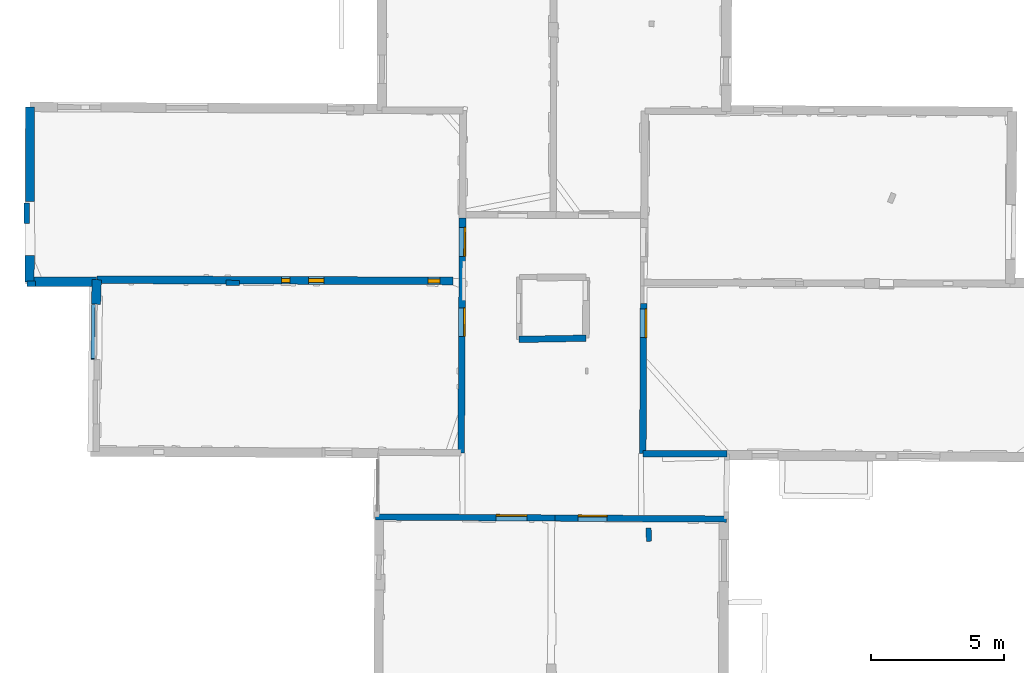
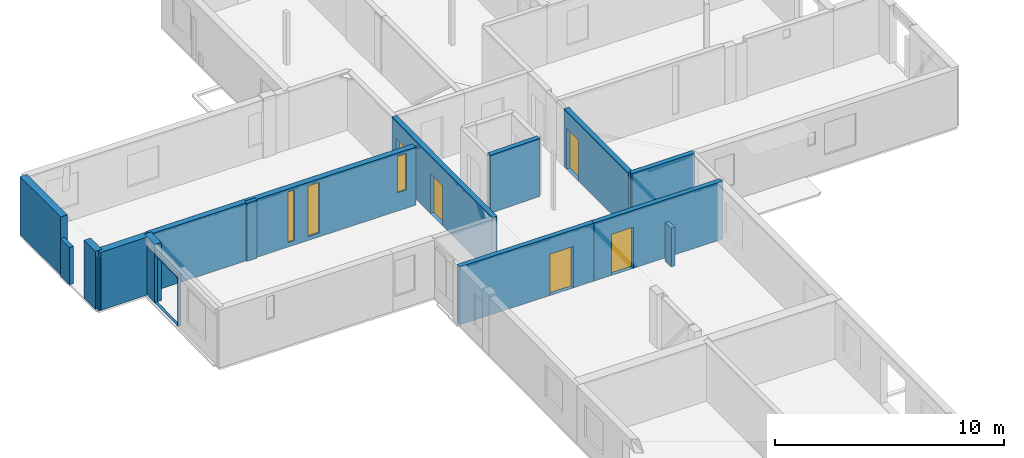
# One storey, part 9 of 17: 16 walls, 5 doors, 3 windows, 9 openings.
"""IFC2X3 building model written with IfcOpenShell, lengths in metres."""

from ifc_helpers import new_model, entity, si_unit, converted_unit, derived_unit, direction, frame, frame_2d, origin, origin_2d_with_axis, place, context, subcontext, project, spatial, polyline, rectangle, outline, extrude, clip, halfspace, source, transform, mapped, material, layer, layer_set, layer_usage, type_object, type_shapes, element, fill, save


model = new_model("IFC2X3")

# Units and contexts
model_context = context("Model", 3, precision=1e-05, world=origin(), true_north=direction((0.0, 1.0)))
body_context = subcontext(model_context, "Body", "Model", "MODEL_VIEW")
ifc_project = project(units=[si_unit("LENGTHUNIT", "METRE"), si_unit("AREAUNIT", "SQUARE_METRE"), si_unit("VOLUMEUNIT", "CUBIC_METRE"), converted_unit("PLANEANGLEUNIT", "DEGREE", entity("IfcRatioMeasure", 0.0174532925199433), si_unit("PLANEANGLEUNIT", "RADIAN"), dimensions=[0, 0, 0, 0, 0, 0, 0]), si_unit("MASSUNIT", "GRAM", prefix="KILO"), derived_unit("MASSDENSITYUNIT", [(si_unit("MASSUNIT", "GRAM", prefix="KILO"), 1), (si_unit("LENGTHUNIT", "METRE"), -3)]), derived_unit("MOMENTOFINERTIAUNIT", [(si_unit("LENGTHUNIT", "METRE"), 4)]), si_unit("TIMEUNIT", "SECOND"), si_unit("FREQUENCYUNIT", "HERTZ"), si_unit("THERMODYNAMICTEMPERATUREUNIT", "DEGREE_CELSIUS"), derived_unit("THERMALTRANSMITTANCEUNIT", [(si_unit("MASSUNIT", "GRAM", prefix="KILO"), 1), (si_unit("THERMODYNAMICTEMPERATUREUNIT", "KELVIN"), -1), (si_unit("TIMEUNIT", "SECOND"), -3)]), derived_unit("VOLUMETRICFLOWRATEUNIT", [(si_unit("LENGTHUNIT", "METRE"), 3), (si_unit("TIMEUNIT", "SECOND"), -1)]), si_unit("ELECTRICCURRENTUNIT", "AMPERE"), si_unit("ELECTRICVOLTAGEUNIT", "VOLT"), si_unit("POWERUNIT", "WATT"), si_unit("FORCEUNIT", "NEWTON", prefix="KILO"), si_unit("ILLUMINANCEUNIT", "LUX"), si_unit("LUMINOUSFLUXUNIT", "LUMEN"), si_unit("LUMINOUSINTENSITYUNIT", "CANDELA"), derived_unit("USERDEFINED", [(si_unit("MASSUNIT", "GRAM", prefix="KILO"), -1), (si_unit("LENGTHUNIT", "METRE"), -2), (si_unit("TIMEUNIT", "SECOND"), 3), (si_unit("LUMINOUSFLUXUNIT", "LUMEN"), 1)]), derived_unit("LINEARVELOCITYUNIT", [(si_unit("LENGTHUNIT", "METRE"), 1), (si_unit("TIMEUNIT", "SECOND"), -1)]), si_unit("PRESSUREUNIT", "PASCAL"), derived_unit("USERDEFINED", [(si_unit("LENGTHUNIT", "METRE"), -2), (si_unit("MASSUNIT", "GRAM", prefix="KILO"), 1), (si_unit("TIMEUNIT", "SECOND"), -2)]), derived_unit("LINEARFORCEUNIT", [(si_unit("MASSUNIT", "GRAM", prefix="KILO"), 1), (si_unit("LENGTHUNIT", "METRE"), 1), (si_unit("TIMEUNIT", "SECOND"), -2), (si_unit("LENGTHUNIT", "METRE"), -1)]), derived_unit("PLANARFORCEUNIT", [(si_unit("MASSUNIT", "GRAM", prefix="KILO"), 1), (si_unit("LENGTHUNIT", "METRE"), 1), (si_unit("TIMEUNIT", "SECOND"), -2), (si_unit("LENGTHUNIT", "METRE"), -2)])], contexts=[model_context])

# Site, building, storey
placement = place(None, origin())
site = spatial("IfcSite", under=ifc_project, at=placement, CompositionType="ELEMENT")
building = spatial("IfcBuilding", under=site, at=placement, CompositionType="ELEMENT")
storey_placement = place(placement, frame((0.0, 0.0, 12.0782108306885)))
storey = spatial("IfcBuildingStorey", under=building, at=storey_placement, Name="Level 5", CompositionType="ELEMENT", Elevation=12.0782108306885)

# Wall, openings, doors
ifc_material_1 = material(Name="Default wall")
ifc_layer_1 = layer(ifc_material_1, 0.25)
ifc_layer_set_1 = layer_set([ifc_layer_1], Name="wall_thickness_0.2500")
ifc_layer_usage_1 = layer_usage(ifc_layer_set_1, "AXIS2", "POSITIVE", -0.125)
wall_type_1 = type_object("IfcWallType", Name="wall_thickness_0.2500", PredefinedType="STANDARD", material=ifc_layer_set_1)
wall_1_placement = place(storey_placement, frame((2.97258634511656, 60.0444172473294, 0.0), z_axis=(0.0, 0.0, 1.0), x_axis=(-0.00545394722210246, -0.999985127119248, 0.0)))
wall_1 = element("IfcWallStandardCase", 1, at=wall_1_placement, inside=storey, type_object=wall_type_1, material=ifc_layer_usage_1, Name="Wall:293", ObjectType="Wall", context=body_context, shape_type="Clipping", body=[
    clip(clip(extrude(outline(polyline([(8.83394409982021, -0.125), (8.83394409982021, 0.125), (0.0, 0.125), (0.0, -0.125), (8.83394409982021, -0.125)])), origin(), (0.0, 0.0, 1.0), 3.09134044647217), halfspace(frame((2.3229233307101, -15.7133209596465, 9.01748660239985), z_axis=(0.391125818460587, -0.00175486266709377, 0.920335544565435), x_axis=(0.00269607752572653, 0.999996076035837, 0.000760972341273259)), False)), halfspace(frame((-15.776051598022, -4.32149318367939, 5.79573318480268), z_axis=(0.00071207565798615, -0.389900123542351, 0.920856876289642), x_axis=(0.00052470655725931, 0.920855864477366, 0.389902810378011)), False)),
])
opening_1_placement = place(wall_1_placement, frame((0.35520700321392, -0.125, 0.00578975677490234)))
opening_1 = element("IfcOpeningElement", 2, at=opening_1_placement, cuts=wall_1, Name="Opening : 1085 x 2155 : 246", ObjectType="Opening", context=body_context, shape_type="SweptSolid", body=[
    extrude(rectangle(XDim=1.085, YDim=2.155, at=frame_2d((1.0775, 0.5425), x_axis=(0.0, 1.0))), frame((0.0, 0.0, 0.0), z_axis=(0.0, 1.0, 0.0), x_axis=(0.0, 0.0, 1.0)), (0.0, 0.0, 1.0), 0.25),
])
opening_2_placement = place(wall_1_placement, frame((3.3853538461384, -0.125, 0.00578975677490234)))
opening_2 = element("IfcOpeningElement", 3, at=opening_2_placement, cuts=wall_1, Name="Opening : 1070 x 2125 : 247", ObjectType="Opening", context=body_context, shape_type="SweptSolid", body=[
    extrude(rectangle(XDim=1.07, YDim=2.125, at=frame_2d((1.0625, 0.535), x_axis=(0.0, 1.0))), frame((0.0, 0.0, 0.0), z_axis=(0.0, 1.0, 0.0), x_axis=(0.0, 0.0, 1.0)), (0.0, 0.0, 1.0), 0.25),
])
ifc_material_2 = material(Name="Door Panel")
door_style_1 = type_object("IfcDoorStyle", Name="Door : 1085 x 2155mm", ConstructionType="NOTDEFINED", OperationType="SINGLE_SWING_RIGHT", ParameterTakesPrecedence=False, Sizeable=False, material=ifc_material_2)
shared_shape_1 = source(origin(), body_context, "Body", "SweptSolid", [
    extrude(rectangle(XDim=0.0625, YDim=1.085, at=origin_2d_with_axis()), frame((0.5425, 0.21875, 0.0), z_axis=(0.0, 0.0, 1.0), x_axis=(0.0, 1.0, 0.0)), (0.0, 0.0, 1.0), 2.155),
])
type_shapes(door_style_1, [shared_shape_1])
door_1_placement = place(opening_1_placement, origin())
door_1 = element("IfcDoor", 4, at=door_1_placement, inside=storey, type_object=door_style_1, Name="Door : 1085 x 2155mm : 46", ObjectType="Door : 1085 x 2155mm", OverallHeight=2.155, OverallWidth=1.085, context=body_context, shape_type="MappedRepresentation", body=[
    mapped(shared_shape_1, transform((0.0, 0.0, 0.0), scale=1.0)),
])
fill(opening_1, door_1)
door_style_2 = type_object("IfcDoorStyle", Name="Door : 1070 x 2125mm", ConstructionType="NOTDEFINED", OperationType="SINGLE_SWING_RIGHT", ParameterTakesPrecedence=False, Sizeable=False, material=ifc_material_2)
shared_shape_2 = source(origin(), body_context, "Body", "SweptSolid", [
    extrude(rectangle(XDim=0.0625, YDim=1.07, at=origin_2d_with_axis()), frame((0.535, 0.21875, 0.0), z_axis=(0.0, 0.0, 1.0), x_axis=(0.0, 1.0, 0.0)), (0.0, 0.0, 1.0), 2.125),
])
type_shapes(door_style_2, [shared_shape_2])
door_2_placement = place(opening_2_placement, origin())
door_2 = element("IfcDoor", 5, at=door_2_placement, inside=storey, type_object=door_style_2, Name="Door : 1070 x 2125mm : 47", ObjectType="Door : 1070 x 2125mm", OverallHeight=2.125, OverallWidth=1.07, context=body_context, shape_type="MappedRepresentation", body=[
    mapped(shared_shape_2, transform((0.0, 0.0, 0.0), scale=1.0)),
])
fill(opening_2, door_2)

# Wall, opening, door
wall_2_placement = place(storey_placement, frame((9.78507749361691, 56.829574594409, 0.0), z_axis=(0.0, 0.0, 1.0), x_axis=(-0.00491332760453561, -0.999987929533077, 0.0)))
wall_2 = element("IfcWallStandardCase", 6, at=wall_2_placement, inside=storey, type_object=wall_type_1, material=ifc_layer_usage_1, Name="Wall:296", ObjectType="Wall", context=body_context, shape_type="Clipping", body=[
    clip(clip(extrude(outline(polyline([(5.64945936592881, -0.125), (5.64945936592881, 0.125), (0.0, 0.125), (0.0, -0.125), (5.64945936592881, -0.125)])), origin(), (0.0, 0.0, 1.0), 3.09134044647217), halfspace(frame((-0.866903899601547, -22.5427789917732, 9.01748660239985), z_axis=(0.391124812576068, -0.00196631553421412, 0.920335544565435), x_axis=(0.00323670187153783, 0.999994472325768, 0.000760972341273259)), False)), halfspace(frame((-20.421691617326, 2.93114393111947, 6.35864093399329), z_axis=(-1.48563875049452e-05, 0.390500122452484, 0.920602875372374), x_axis=(0.673609083494681, -0.680402403832266, 0.288623234499112)), False)),
])
opening_3_placement = place(wall_2_placement, frame((0.200724172085112, -0.125, 0.00578975677490234)))
opening_3 = element("IfcOpeningElement", 7, at=opening_3_placement, cuts=wall_2, Name="Opening : 1085 x 2185 : 249", ObjectType="Opening", context=body_context, shape_type="SweptSolid", body=[
    extrude(rectangle(XDim=1.085, YDim=2.185, at=frame_2d((1.0925, 0.5425), x_axis=(0.0, 1.0))), frame((0.0, 0.0, 0.0), z_axis=(0.0, 1.0, 0.0), x_axis=(0.0, 0.0, 1.0)), (0.0, 0.0, 1.0), 0.25),
])
door_style_3 = type_object("IfcDoorStyle", Name="Door : 1085 x 2185mm", ConstructionType="NOTDEFINED", OperationType="SINGLE_SWING_RIGHT", ParameterTakesPrecedence=False, Sizeable=False, material=ifc_material_2)
shared_shape_3 = source(origin(), body_context, "Body", "SweptSolid", [
    extrude(rectangle(XDim=0.0625, YDim=1.085, at=origin_2d_with_axis()), frame((0.5425, 0.21875, 0.0), z_axis=(0.0, 0.0, 1.0), x_axis=(0.0, 1.0, 0.0)), (0.0, 0.0, 1.0), 2.185),
])
type_shapes(door_style_3, [shared_shape_3])
door_3_placement = place(opening_3_placement, origin())
door_3 = element("IfcDoor", 8, at=door_3_placement, inside=storey, type_object=door_style_3, Name="Door : 1085 x 2185mm : 49", ObjectType="Door : 1085 x 2185mm", OverallHeight=2.185, OverallWidth=1.085, context=body_context, shape_type="MappedRepresentation", body=[
    mapped(shared_shape_3, transform((0.0, 0.0, 0.0), scale=1.0)),
])
fill(opening_3, door_3)

# Walls
ifc_layer_2 = layer(ifc_material_1, 0.349999994039536)
ifc_layer_set_2 = layer_set([ifc_layer_2], Name="wall_thickness_0.3500")
ifc_layer_usage_2 = layer_usage(ifc_layer_set_2, "AXIS2", "POSITIVE", -0.174999997019768)
wall_type_2 = type_object("IfcWallType", Name="wall_thickness_0.3500", PredefinedType="STANDARD", material=ifc_layer_set_2)
wall_3_placement = place(storey_placement, frame((-10.786523732517, 57.7226371348362, 0.0), z_axis=(0.0, 0.0, 1.0), x_axis=(-0.0302345456324887, -0.999542831623736, 0.0)))
element("IfcWallStandardCase", 9, at=wall_3_placement, inside=storey, type_object=wall_type_2, material=ifc_layer_usage_2, Name="Wall:325", ObjectType="Wall", context=body_context, shape_type="Clipping", body=[
    clip(extrude(outline(polyline([(0.922556162917075, -0.174999997019768), (0.922556162917075, 0.174999997019768), (0.0, 0.174999997019768), (0.0, -0.174999997019768), (0.922556162917075, -0.174999997019768)])), origin(), (0.0, 0.0, 1.0), 3.09134044647217), halfspace(frame((-0.0250916245106704, -1.9683047614688, 9.01748660239985), z_axis=(0.391049179445526, 0.00793880749390821, 0.920335544565435), x_axis=(-0.0220872954005997, 0.999755756324005, 0.000760972341273259)), False)),
])
wall_4_placement = place(storey_placement, frame((-13.2988979832564, 64.2230248395409, 0.0), z_axis=(0.0, 0.0, 1.0), x_axis=(-0.00072722175541254, -0.999999735574224, 0.0)))
element("IfcWallStandardCase", 10, at=wall_4_placement, inside=storey, type_object=wall_type_2, material=ifc_layer_usage_2, Name="Wall:353", ObjectType="Wall", context=body_context, shape_type="SweptSolid", body=[
    extrude(outline(polyline([(3.55125521150435, -0.174999997019768), (3.55125521150435, 0.174999997019768), (0.0, 0.174999997019768), (0.0, -0.174999997019768), (3.55125521150435, -0.174999997019768)])), origin(), (0.0, 0.0, 1.0), 3.09134044647217),
])
ifc_layer_3 = layer(ifc_material_1, 0.2)
ifc_layer_set_3 = layer_set([ifc_layer_3], Name="wall_thickness_0.2000")
ifc_layer_usage_3 = layer_usage(ifc_layer_set_3, "AXIS2", "POSITIVE", -0.1)
wall_type_3 = type_object("IfcWallType", Name="wall_thickness_0.2000", PredefinedType="STANDARD", material=ifc_layer_set_3)
wall_5_placement = place(storey_placement, frame((-5.92594383292661, 57.6032597839898, 0.0), z_axis=(0.0, 0.0, 1.0), x_axis=(0.999982178277312, -0.00597018657677781, 0.0)))
element("IfcWallStandardCase", 11, at=wall_5_placement, inside=storey, type_object=wall_type_3, material=ifc_layer_usage_3, Name="Wall:298", ObjectType="Wall", context=body_context, shape_type="Clipping", body=[
    clip(extrude(outline(polyline([(0.514999984766503, -0.1), (0.514999984766503, 0.1), (0.0, 0.1), (0.0, -0.1), (0.514999984766503, -0.1)])), origin(), (0.0, 0.0, 1.0), 3.09134044647217), halfspace(frame((-6.82832223640236, 0.163204855223103, 9.01748660239985), z_axis=(-0.00155294460577056, -0.391126672284691, 0.920335544565435), x_axis=(0.999997334624458, -0.00217983143265884, 0.000760972341273259)), False)),
])
wall_6_placement = place(storey_placement, frame((-13.4037424072061, 57.5677008523582, 0.0), z_axis=(0.0, 0.0, 1.0), x_axis=(0.999998958154798, 0.001443498984781, 0.0)))
element("IfcWallStandardCase", 12, at=wall_6_placement, inside=storey, type_object=wall_type_3, material=ifc_layer_usage_3, Name="Wall:317", ObjectType="Wall", context=body_context, shape_type="SweptSolid", body=[
    extrude(outline(polyline([(0.317120882453858, -0.1), (0.317120882453858, 0.1), (0.0, 0.1), (0.0, -0.1), (0.317120882453858, -0.1)])), origin(), (0.0, 0.0, 1.0), 2.77079010009766),
])
wall_7_placement = place(storey_placement, frame((9.96924737158519, 48.3854746875862, 0.0), z_axis=(0.0, 0.0, 1.0), x_axis=(0.0427961878833052, -0.999083823461604, 0.0)))
element("IfcWallStandardCase", 13, at=wall_7_placement, inside=storey, type_object=wall_type_3, material=ifc_layer_usage_3, Name="Wall:346", ObjectType="Wall", context=body_context, shape_type="Clipping", body=[
    clip(extrude(outline(polyline([(0.505002160877729, -0.1), (0.505002160877729, 0.1), (0.0, 0.1), (0.0, -0.1), (0.505002160877729, -0.1)])), origin(), (0.0, 0.0, 1.0), 2.07478904724121), halfspace(frame((-28.7028580065749, 4.07938747716486, 6.35864093399329), z_axis=(0.0186137726193946, 0.390056243796956, 0.920602875372374), x_axis=(0.640383919674725, -0.711761943299378, 0.288623234499112)), False)),
])
wall_8_placement = place(storey_placement, frame((-13.4191786365824, 59.829089680565, 0.0), z_axis=(0.0, 0.0, 1.0), x_axis=(-0.00423869144538484, 0.999991016707066, 0.0)))
element("IfcWallStandardCase", 14, at=wall_8_placement, inside=storey, type_object=wall_type_3, material=ifc_layer_usage_3, Name="Wall:350", ObjectType="Wall", context=body_context, shape_type="SweptSolid", body=[
    extrude(outline(polyline([(0.784999269895973, -0.1), (0.784999269895973, 0.1), (0.0, 0.1), (0.0, -0.1), (0.784999269895973, -0.1)])), origin(), (0.0, 0.0, 1.0), 1.99078941345215),
])
ifc_layer_4 = layer(ifc_material_1, 0.239999994635582)
ifc_layer_set_4 = layer_set([ifc_layer_4], Name="wall_thickness_0.2400")
ifc_layer_usage_4 = layer_usage(ifc_layer_set_4, "AXIS2", "POSITIVE", -0.119999997317791)
wall_type_4 = type_object("IfcWallType", Name="wall_thickness_0.2400", PredefinedType="STANDARD", material=ifc_layer_set_4)
wall_9_placement = place(storey_placement, frame((9.75732022944128, 51.1801839236183, 0.0), z_axis=(0.0, 0.0, 1.0), x_axis=(0.999995397319388, -0.00303403032941338, 0.0)))
element("IfcWallStandardCase", 15, at=wall_9_placement, inside=storey, type_object=wall_type_4, material=ifc_layer_usage_4, Name="Wall:254", ObjectType="Wall", context=body_context, shape_type="Clipping", body=[
    clip(clip(extrude(outline(polyline([(3.16086125863991, -0.119999997317791), (3.16086125863991, 0.119999997317791), (0.0, 0.119999997317791), (0.0, -0.119999997317791), (3.16086125863991, -0.119999997317791)])), origin(), (0.0, 0.0, 1.0), 3.09134044647217), halfspace(frame((-22.5304932872622, 6.55871615246608, 9.01748660239985), z_axis=(-0.00270135733514378, -0.391120426567052, 0.920335544565435), x_axis=(0.999986623658175, -0.00511599705040992, 0.000760972341273259)), False)), halfspace(frame((2.98013418424224, 26.0655959074875, 6.35864093399329), z_axis=(0.390499460785358, -0.000719014924792586, 0.920602875372374), x_axis=(-0.681667123455706, -0.672329206049309, 0.288623234499112)), False)),
])
wall_10_placement = place(storey_placement, frame((5.10258269672159, 55.4764295225609, 0.0), z_axis=(0.0, 0.0, 1.0), x_axis=(0.999836645621068, 0.0180743484864693, 0.0)))
element("IfcWallStandardCase", 16, at=wall_10_placement, inside=storey, type_object=wall_type_4, material=ifc_layer_usage_4, Name="Wall:345", ObjectType="Wall", context=body_context, shape_type="Clipping", body=[
    clip(clip(extrude(outline(polyline([(2.5128311362665, -0.119999997317791), (2.5128311362665, 0.119999997317791), (0.0, 0.119999997317791), (0.0, -0.119999997317791), (2.5128311362665, -0.119999997317791)])), origin(), (0.0, 0.0, 1.0), 3.09134044647217), halfspace(frame((-17.8107082292246, 2.65314891663737, 9.01748660239985), z_axis=(-0.0109564472289568, -0.390976267404511, 0.920335544565435), x_axis=(0.999655844766623, -0.0262223748929086, 0.000760972341273259)), False)), halfspace(frame((8.10598293315181, 21.617209424892, 6.35864093399329), z_axis=(0.39039728285767, -0.00896143925192244, 0.920602875372374), x_axis=(-0.695706642235711, -0.657790921536914, 0.288623234499112)), False)),
])

# Wall, opening, door
wall_11_placement = place(storey_placement, frame((-0.294860350991049, 48.7982074961249, 0.0), z_axis=(0.0, 0.0, 1.0), x_axis=(0.99998139879022, -0.00609935025680136, 0.0)))
wall_11 = element("IfcWallStandardCase", 17, at=wall_11_placement, inside=storey, type_object=wall_type_4, material=ifc_layer_usage_4, Name="Wall:362", ObjectType="Wall", context=body_context, shape_type="Clipping", body=[
    clip(extrude(outline(polyline([(6.73897403928807, -0.119999997317791), (6.73897403928807, 0.119999997317791), (0.0, 0.119999997317791), (0.0, -0.119999997317791), (6.73897403928807, -0.119999997317791)])), origin(), (0.0, 0.0, 1.0), 3.09134044647217), halfspace(frame((-1.13288301922341, 27.0391890209298, 5.79573318480268), z_axis=(-0.389899582750718, -0.000963722418258772, 0.920856876289642), x_axis=(0.920856011334815, 6.96266069676336e-05, 0.389902810378011)), False)),
])
opening_4_placement = place(wall_11_placement, frame((4.53266471568359, -0.119999997317791, 0.00578975677490234)))
opening_4 = element("IfcOpeningElement", 18, at=opening_4_placement, cuts=wall_11, Name="Opening : 1160 x 2200 : 299", ObjectType="Opening", context=body_context, shape_type="SweptSolid", body=[
    extrude(rectangle(XDim=1.16, YDim=2.2, at=frame_2d((1.1, 0.58), x_axis=(0.0, 1.0))), frame((0.0, 0.0, 0.0), z_axis=(0.0, 1.0, 0.0), x_axis=(0.0, 0.0, 1.0)), (0.0, 0.0, 1.0), 0.239999994635582),
])
door_style_4 = type_object("IfcDoorStyle", Name="Door : 1160 x 2200mm", ConstructionType="NOTDEFINED", OperationType="SINGLE_SWING_RIGHT", ParameterTakesPrecedence=False, Sizeable=False, material=ifc_material_2)
shared_shape_4 = source(origin(), body_context, "Body", "SweptSolid", [
    extrude(rectangle(XDim=0.0599999986588955, YDim=1.16, at=origin_2d_with_axis()), frame((0.58, 0.209999995306134, 0.0), z_axis=(0.0, 0.0, 1.0), x_axis=(0.0, 1.0, 0.0)), (0.0, 0.0, 1.0), 2.2),
])
type_shapes(door_style_4, [shared_shape_4])
door_4_placement = place(opening_4_placement, origin())
door_4 = element("IfcDoor", 19, at=door_4_placement, inside=storey, type_object=door_style_4, Name="Door : 1160 x 2200mm : 53", ObjectType="Door : 1160 x 2200mm", OverallHeight=2.2, OverallWidth=1.16, context=body_context, shape_type="MappedRepresentation", body=[
    mapped(shared_shape_4, transform((0.0, 0.0, 0.0), scale=1.0)),
])
fill(opening_4, door_4)

wall_12_placement = place(storey_placement, frame((6.44398833522721, 48.7571041330878, 0.0), z_axis=(0.0, 0.0, 1.0), x_axis=(0.999981397722658, -0.00609952527990835, 0.0)))
wall_12 = element("IfcWallStandardCase", 20, at=wall_12_placement, inside=storey, type_object=wall_type_4, material=ifc_layer_usage_4, Name="Wall:363", ObjectType="Wall", context=body_context, shape_type="Clipping", body=[
    clip(extrude(outline(polyline([(6.46234994312466, -0.119999997317791), (6.46234994312466, 0.119999997317791), (0.0, 0.119999997317791), (0.0, -0.119999997317791), (6.46234994312466, -0.119999997317791)])), origin(), (0.0, 0.0, 1.0), 3.09134044647217), halfspace(frame((6.19870611165594, 28.5178535705564, 6.35864093399329), z_axis=(0.390499830091764, 0.000478073655664486, 0.920602875372374), x_axis=(-0.679602879630244, -0.674415713418327, 0.288623234499112)), False)),
])
opening_5_placement = place(wall_12_placement, frame((0.878690866385546, -0.119999997317791, 0.00578975677490234)))
opening_5 = element("IfcOpeningElement", 21, at=opening_5_placement, cuts=wall_12, Name="Opening : 1090 x 2185 : 300", ObjectType="Opening", context=body_context, shape_type="SweptSolid", body=[
    extrude(rectangle(XDim=1.09, YDim=2.185, at=frame_2d((1.0925, 0.545), x_axis=(0.0, 1.0))), frame((0.0, 0.0, 0.0), z_axis=(0.0, 1.0, 0.0), x_axis=(0.0, 0.0, 1.0)), (0.0, 0.0, 1.0), 0.239999994635582),
])
door_style_5 = type_object("IfcDoorStyle", Name="Door : 1090 x 2185mm", ConstructionType="NOTDEFINED", OperationType="SINGLE_SWING_RIGHT", ParameterTakesPrecedence=False, Sizeable=False, material=ifc_material_2)
shared_shape_5 = source(origin(), body_context, "Body", "SweptSolid", [
    extrude(rectangle(XDim=0.0599999986588955, YDim=1.09, at=origin_2d_with_axis()), frame((0.545, 0.209999995306134, 0.0), z_axis=(0.0, 0.0, 1.0), x_axis=(0.0, 1.0, 0.0)), (0.0, 0.0, 1.0), 2.185),
])
type_shapes(door_style_5, [shared_shape_5])
door_5_placement = place(opening_5_placement, origin())
door_5 = element("IfcDoor", 22, at=door_5_placement, inside=storey, type_object=door_style_5, Name="Door : 1090 x 2185mm : 54", ObjectType="Door : 1090 x 2185mm", OverallHeight=2.185, OverallWidth=1.09, context=body_context, shape_type="MappedRepresentation", body=[
    mapped(shared_shape_5, transform((0.0, 0.0, 0.0), scale=1.0)),
])
fill(opening_5, door_5)

# Walls
ifc_layer_5 = layer(ifc_material_1, 0.340000003576279)
ifc_layer_set_5 = layer_set([ifc_layer_5], Name="wall_thickness_0.3400")
ifc_layer_usage_5 = layer_usage(ifc_layer_set_5, "AXIS2", "POSITIVE", -0.170000001788139)
wall_type_5 = type_object("IfcWallType", Name="wall_thickness_0.3400", PredefinedType="STANDARD", material=ifc_layer_set_5)
wall_13_placement = place(storey_placement, frame((-13.3069939851436, 58.6288491921061, 0.0), z_axis=(0.0, 0.0, 1.0), x_axis=(-0.00211108228265177, -0.999997771663315, 0.0)))
element("IfcWallStandardCase", 23, at=wall_13_placement, inside=storey, type_object=wall_type_5, material=ifc_layer_usage_5, Name="Wall:311", ObjectType="Wall", context=body_context, shape_type="SweptSolid", body=[
    extrude(outline(polyline([(0.983904170008819, -0.170000001788139), (0.983904170008819, 0.170000001788139), (0.0, 0.170000001788139), (0.0, -0.170000001788139), (0.983904170008819, -0.170000001788139)])), origin(), (0.0, 0.0, 1.0), 3.09134044647217),
])
ifc_layer_6 = layer(ifc_material_1, 0.360000014305115)
ifc_layer_set_6 = layer_set([ifc_layer_6], Name="wall_thickness_0.3600")
ifc_layer_usage_6 = layer_usage(ifc_layer_set_6, "AXIS2", "POSITIVE", -0.180000007152557)
wall_type_6 = type_object("IfcWallType", Name="wall_thickness_0.3600", PredefinedType="STANDARD", material=ifc_layer_set_6)
wall_14_placement = place(storey_placement, frame((-13.3090709443127, 57.644948042717, 0.0), z_axis=(0.0, 0.0, 1.0), x_axis=(0.999996147484477, 0.0027757910951651, 0.0)))
element("IfcWallStandardCase", 24, at=wall_14_placement, inside=storey, type_object=wall_type_6, material=ifc_layer_usage_6, Name="Wall:358", ObjectType="Wall", context=body_context, shape_type="Clipping", body=[
    clip(extrude(outline(polyline([(2.52041834032187, -0.180000007152557), (2.52041834032187, 0.180000007152557), (0.0, 0.180000007152557), (0.0, -0.180000007152557), (2.52041834032187, -0.180000007152557)])), origin(), (0.0, 0.0, 1.0), 3.09134044647217), halfspace(frame((0.556349244773657, 0.160736355621769, 9.01748660239985), z_axis=(-0.00497364200950589, -0.391098131284983, 0.920335544565435), x_axis=(0.999940023967043, -0.010925629953682, 0.000760972341273259)), False)),
])

# Wall, openings, windows
ifc_layer_7 = layer(ifc_material_1, 0.28999999165535)
ifc_layer_set_7 = layer_set([ifc_layer_7], Name="wall_thickness_0.2900")
ifc_layer_usage_7 = layer_usage(ifc_layer_set_7, "AXIS2", "POSITIVE", -0.144999995827675)
wall_type_7 = type_object("IfcWallType", Name="wall_thickness_0.2900", PredefinedType="STANDARD", material=ifc_layer_set_7)
wall_15_placement = place(storey_placement, frame((-10.7865238037063, 57.7226434762087, 0.0), z_axis=(0.0, 0.0, 1.0), x_axis=(0.999994014487029, -0.00345991186527063, 0.0)))
wall_15 = element("IfcWallStandardCase", 25, at=wall_15_placement, inside=storey, type_object=wall_type_7, material=ifc_layer_usage_7, Name="Wall:291", ObjectType="Wall", context=body_context, shape_type="Clipping", body=[
    clip(extrude(outline(polyline([(13.3958822022533, -0.144999995827675), (13.3958822022533, 0.144999995827675), (0.0, 0.144999995827675), (0.0, -0.144999995827675), (13.3958822022533, -0.144999995827675)])), origin(), (0.0, 0.0, 1.0), 3.09134044647217), halfspace(frame((-1.96692709363834, 0.0777796833321555, 9.01748660239985), z_axis=(-0.00253478524789581, -0.391121541561177, 0.920335544565435), x_axis=(0.999988711791008, -0.00469011851199887, 0.00076097234127326)), False)),
])
opening_6_placement = place(wall_15_placement, frame((6.95353239618624, -0.144999995827675, 0.23578929901123)))
opening_6 = element("IfcOpeningElement", 26, at=opening_6_placement, cuts=wall_15, Name="Opening : 325 x 2695 : 243", ObjectType="Opening", context=body_context, shape_type="SweptSolid", body=[
    extrude(rectangle(XDim=0.325, YDim=2.695, at=frame_2d((1.3475, 0.1625), x_axis=(0.0, 1.0))), frame((0.0, 0.0, 0.0), z_axis=(0.0, 1.0, 0.0), x_axis=(0.0, 0.0, 1.0)), (0.0, 0.0, 1.0), 0.28999999165535),
])
opening_7_placement = place(wall_15_placement, frame((7.95853232018836, -0.144999995827675, 0.205789566040039)))
opening_7 = element("IfcOpeningElement", 27, at=opening_7_placement, cuts=wall_15, Name="Opening : 585 x 2700 : 244", ObjectType="Opening", context=body_context, shape_type="SweptSolid", body=[
    extrude(rectangle(XDim=0.585, YDim=2.7, at=frame_2d((1.35, 0.2925), x_axis=(0.0, 1.0))), frame((0.0, 0.0, 0.0), z_axis=(0.0, 1.0, 0.0), x_axis=(0.0, 0.0, 1.0)), (0.0, 0.0, 1.0), 0.28999999165535),
])
opening_8_placement = place(wall_15_placement, frame((12.4658148516858, -0.144999995827675, 0.970788955688477)))
opening_8 = element("IfcOpeningElement", 28, at=opening_8_placement, cuts=wall_15, Name="Opening : 450 x 1935 : 245", ObjectType="Opening", context=body_context, shape_type="SweptSolid", body=[
    extrude(rectangle(XDim=0.45, YDim=1.935, at=frame_2d((0.9675, 0.225), x_axis=(0.0, 1.0))), frame((0.0, 0.0, 0.0), z_axis=(0.0, 1.0, 0.0), x_axis=(0.0, 0.0, 1.0)), (0.0, 0.0, 1.0), 0.28999999165535),
])
ifc_material_3 = material(Name="Window Default")
window_style_1 = type_object("IfcWindowStyle", Name="Window : 325 x 2695mm", ConstructionType="NOTDEFINED", OperationType="NOTDEFINED", ParameterTakesPrecedence=False, Sizeable=False, material=ifc_material_3)
shared_shape_6 = source(origin(), body_context, "Body", "SweptSolid", [
    extrude(rectangle(XDim=0.144999995827675, YDim=0.325, at=origin_2d_with_axis()), frame((0.1625, 0.144999995827675, 0.0), z_axis=(0.0, 0.0, 1.0), x_axis=(0.0, 1.0, 0.0)), (0.0, 0.0, 1.0), 2.695),
])
type_shapes(window_style_1, [shared_shape_6])
window_1_placement = place(opening_6_placement, origin())
window_1 = element("IfcWindow", 29, at=window_1_placement, inside=storey, type_object=window_style_1, Name="Window : 325 x 2695mm : 130", ObjectType="Window : 325 x 2695mm", OverallHeight=2.695, OverallWidth=0.325, context=body_context, shape_type="MappedRepresentation", body=[
    mapped(shared_shape_6, transform((0.0, 0.0, 0.0), scale=1.0)),
])
fill(opening_6, window_1)
window_style_2 = type_object("IfcWindowStyle", Name="Window : 585 x 2700mm", ConstructionType="NOTDEFINED", OperationType="NOTDEFINED", ParameterTakesPrecedence=False, Sizeable=False, material=ifc_material_3)
shared_shape_7 = source(origin(), body_context, "Body", "SweptSolid", [
    extrude(rectangle(XDim=0.144999995827675, YDim=0.585, at=origin_2d_with_axis()), frame((0.2925, 0.144999995827675, 0.0), z_axis=(0.0, 0.0, 1.0), x_axis=(0.0, 1.0, 0.0)), (0.0, 0.0, 1.0), 2.7),
])
type_shapes(window_style_2, [shared_shape_7])
window_2_placement = place(opening_7_placement, origin())
window_2 = element("IfcWindow", 30, at=window_2_placement, inside=storey, type_object=window_style_2, Name="Window : 585 x 2700mm : 131", ObjectType="Window : 585 x 2700mm", OverallHeight=2.7, OverallWidth=0.585, context=body_context, shape_type="MappedRepresentation", body=[
    mapped(shared_shape_7, transform((0.0, 0.0, 0.0), scale=1.0)),
])
fill(opening_7, window_2)
window_style_3 = type_object("IfcWindowStyle", Name="Window : 450 x 1935mm", ConstructionType="NOTDEFINED", OperationType="NOTDEFINED", ParameterTakesPrecedence=False, Sizeable=False, material=ifc_material_3)
shared_shape_8 = source(origin(), body_context, "Body", "SweptSolid", [
    extrude(rectangle(XDim=0.144999995827675, YDim=0.45, at=origin_2d_with_axis()), frame((0.225, 0.144999995827675, 0.0), z_axis=(0.0, 0.0, 1.0), x_axis=(0.0, 1.0, 0.0)), (0.0, 0.0, 1.0), 1.935),
])
type_shapes(window_style_3, [shared_shape_8])
window_3_placement = place(opening_8_placement, origin())
window_3 = element("IfcWindow", 31, at=window_3_placement, inside=storey, type_object=window_style_3, Name="Window : 450 x 1935mm : 132", ObjectType="Window : 450 x 1935mm", OverallHeight=1.935, OverallWidth=0.45, context=body_context, shape_type="MappedRepresentation", body=[
    mapped(shared_shape_8, transform((0.0, 0.0, 0.0), scale=1.0)),
])
fill(opening_8, window_3)

# Wall, opening
ifc_layer_8 = layer(ifc_material_1, 0.140000000596046)
ifc_layer_set_8 = layer_set([ifc_layer_8], Name="wall_thickness_0.1400")
ifc_layer_usage_8 = layer_usage(ifc_layer_set_8, "AXIS2", "POSITIVE", -0.0700000002980232)
wall_type_8 = type_object("IfcWallType", Name="wall_thickness_0.1400", PredefinedType="STANDARD", material=ifc_layer_set_8)
wall_16_placement = place(storey_placement, frame((-10.9121936440506, 56.7975429913065, 0.0), z_axis=(0.0, 0.0, 1.0), x_axis=(-0.00854966429305378, -0.999963450952322, 0.0)))
wall_16 = element("IfcWallStandardCase", 32, at=wall_16_placement, inside=storey, type_object=wall_type_8, material=ifc_layer_usage_8, Name="Wall:354", ObjectType="Wall", context=body_context, shape_type="Clipping", body=[
    clip(extrude(outline(polyline([(2.07886855268733, -0.0700000002980232), (2.07886855268733, 0.0700000002980232), (0.0, 0.0700000002980232), (0.0, -0.0700000002980232), (2.07886855268733, -0.0700000002980232)])), origin(), (0.0, 0.0, 1.0), 2.77079010009766), halfspace(frame((-0.993908464114077, -1.84954155206566, 9.01748660239985), z_axis=(0.391129376883543, -0.000544011153900256, 0.920335544565435), x_axis=(-0.000399712495412847, 0.99999963057544, 0.000760972341273259)), False)),
])
opening_9_placement = place(wall_16_placement, frame((0.00356686081429062, -0.0700000002980232, 0.00578975677490234)))
element("IfcOpeningElement", 33, at=opening_9_placement, cuts=wall_16, Name="Opening : 2035 x 2550 : 293", ObjectType="Opening", context=body_context, shape_type="SweptSolid", body=[
    extrude(rectangle(XDim=2.035, YDim=2.55, at=frame_2d((1.275, 1.0175), x_axis=(0.0, 1.0))), frame((0.0, 0.0, 0.0), z_axis=(0.0, 1.0, 0.0), x_axis=(0.0, 0.0, 1.0)), (0.0, 0.0, 1.0), 0.140000000596046),
])

save(model, "model.ifc")
